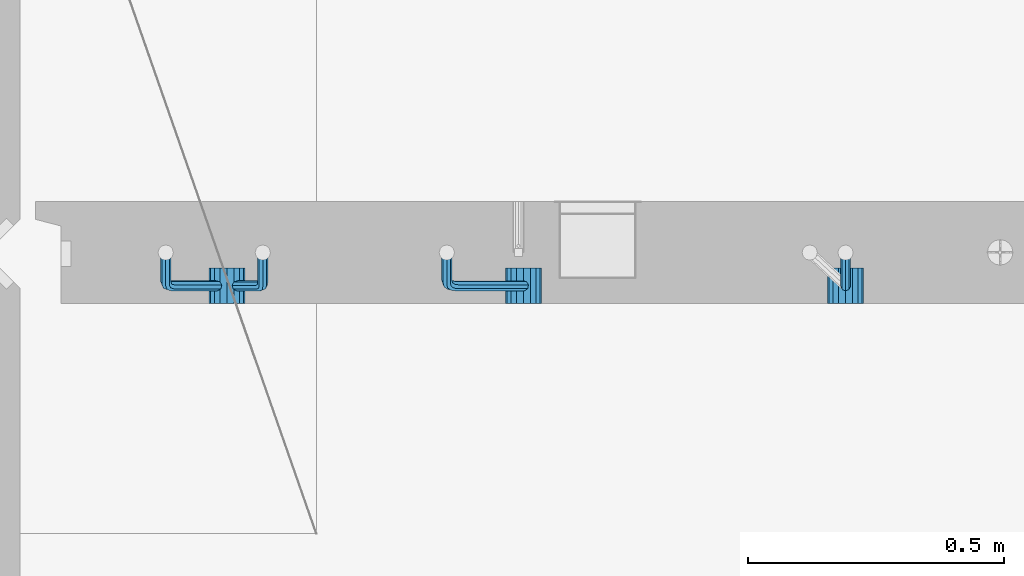
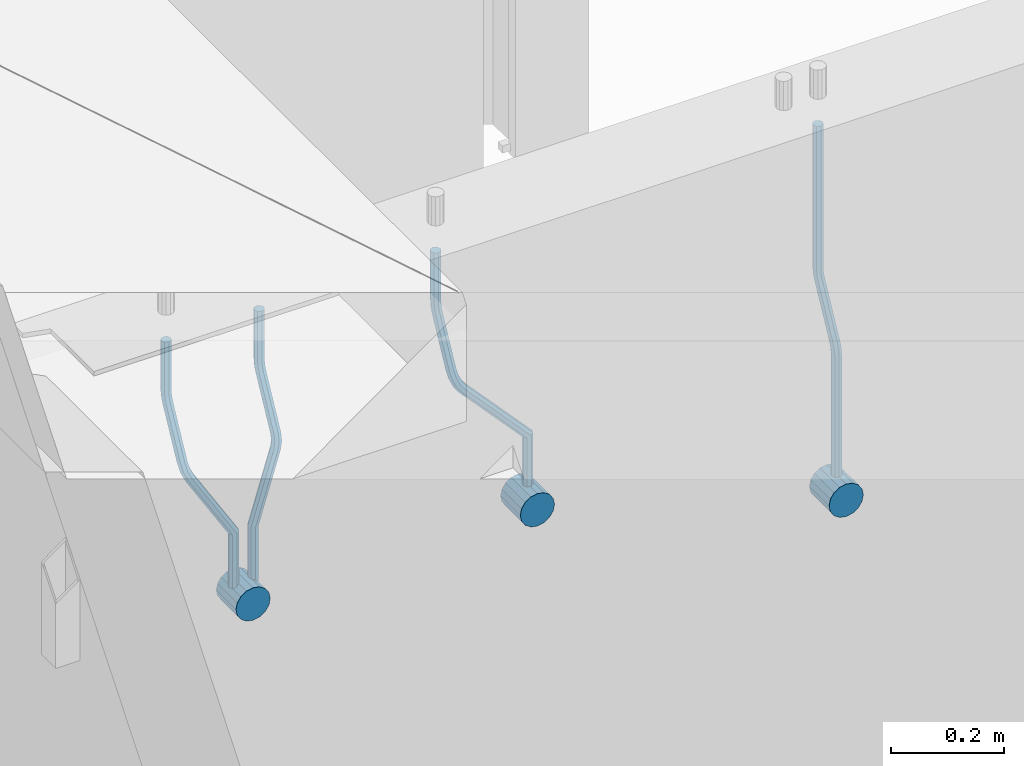
# One storey, part 155 of 350: 7 beams, 1 element without a shape of its own.
"""IFC2X3 building model written with IfcOpenShell, lengths in millimetres."""

from ifc_helpers import new_model, si_unit, frame, origin_with_axes, place, context, subcontext, project, spatial, faceted_brep, material, type_object, element, aggregate, save


model = new_model("IFC2X3")

# Units and contexts
model_context = context("Model", 3, precision=1e-05, world=origin_with_axes())
body_context = subcontext(model_context, "Body", "Model", "MODEL_VIEW")
ifc_project = project(units=[si_unit("LENGTHUNIT", "METRE", prefix="MILLI"), si_unit("AREAUNIT", "SQUARE_METRE"), si_unit("VOLUMEUNIT", "CUBIC_METRE"), si_unit("MASSUNIT", "GRAM", prefix="KILO"), si_unit("TIMEUNIT", "SECOND"), si_unit("PLANEANGLEUNIT", "RADIAN"), si_unit("SOLIDANGLEUNIT", "STERADIAN"), si_unit("THERMODYNAMICTEMPERATUREUNIT", "DEGREE_CELSIUS"), si_unit("LUMINOUSINTENSITYUNIT", "LUMEN")], contexts=[model_context])

# Site, building, storey
site_placement = place(None, origin_with_axes())
site = spatial("IfcSite", under=ifc_project, at=site_placement, CompositionType="ELEMENT")
building_placement = place(site_placement, origin_with_axes())
building = spatial("IfcBuilding", under=site, at=building_placement, CompositionType="ELEMENT")
storey_placement = place(building_placement, origin_with_axes())
storey = spatial("IfcBuildingStorey", under=building, at=storey_placement, Name="2", CompositionType="ELEMENT", Elevation=0.0)

# Assembly, beams
assembly_placement = place(storey_placement, origin_with_axes())
assembly = element("IfcElementAssembly", 1, at=assembly_placement, inside=storey, AssemblyPlace="NOTDEFINED", PredefinedType="REINFORCEMENT_UNIT")
ifc_material = material()
beam_type_1 = type_object("IfcBeamType", Name="D20", PredefinedType="NOTDEFINED")
beam_1_placement = place(assembly_placement, frame((9615.0034031366, 16979.9000008034, 87407.5), z_axis=(-0.000415599999849952, -0.999999913638316, 0.0), x_axis=(0.0, 0.0, -1.0)))
beam_1 = element("IfcBeam", 2, at=beam_1_placement, type_object=beam_type_1, material=ifc_material, Name="JM20", ObjectType="D20", context=body_context, shape_type="Brep", body=[
    faceted_brep([(0.0, -10.0, 0.0), (-4.19531716033816e-08, -7.07106781186667, -7.07106781187031), (308.817759199839, -7.07106784567077, -7.07106781098628), (308.817759199388, -10.0000000315576, 1.18961906991899e-09), (0.0, 0.0, -10.0), (308.817759200625, -3.38059180648997e-08, -9.99999999911961), (4.196772351861e-08, 7.07106781186303, -7.07106781186667), (308.817759201396, 7.07106777806075, -7.07106781098992), (0.0, 10.0, 0.0), (308.817759201687, 9.99999996619408, 8.76752892509103e-10), (4.196772351861e-08, 7.07106781185939, 7.07106781185939), (308.817759201353, 7.07106777805893, 7.07106781273978), (0.0, 0.0, 10.0), (308.817759200567, -3.38059180648997e-08, 10.0000000008768), (-4.19531716033816e-08, -7.07106781187031, 7.07106781185939), (308.817759199781, -7.07106784567259, 7.07106781274342), (323.108969574154, 0.000717635259206872, -8.27316123493802), (322.412036484602, -7.07038517474393, -5.42844102338131), (320.72809124495, -9.99940192615759, 1.43915193649809), (319.043566138222, -7.07055433041933, 8.30667482965873), (318.345233125816, 0.000478413006931078, 11.1512258851908), (319.042166215368, 7.07158122300643, 8.30650567364501), (320.726111455049, 10.0005979744237, 1.4389127137656), (322.410636561748, 7.07175037869092, -5.42861017940231), (335.221090258594, 7.07375888522984, -0.59577927861028), (336.577559329642, 0.00282932867594354, -3.19204402394098), (331.949003496353, 10.0023575726736, 5.67282516818887), (328.678043090971, 7.07309199865631, 11.9417058486688), (327.324293285914, 0.00188620863991673, 14.5386374811205), (328.680762356948, -7.06904334791398, 11.9423727357971), (331.952849119407, -9.99764203791528, 5.67376828873239), (335.223809524556, -7.06837646134409, -0.59511239150379), (438.031978881656, -7.04607830785426, 53.0582885393342), (434.761018476231, -9.97534387865016, 59.3271692200688), (439.385728686641, 0.0251274821457628, 50.4613569068679), (438.02925961549, 7.0960570387233, 53.0576216521513), (434.757172853177, 10.0246557262235, 59.326226098925), (431.486212447766, 7.0953901522571, 65.5951067794085), (430.132462642781, 0.0241843622607121, 68.1920384118748), (431.488931713931, -7.04674519431865, 65.5957736665914), (448.364788846782, 0.0265352911246737, 53.8487685030559), (447.667855771331, -7.04456751813632, 56.6934887198913), (445.983910537514, -9.97358426776555, 63.5610816819462), (444.29938542498, -7.04473667025195, 70.428604572935), (443.601052398531, 0.0262960739091795, 73.2731556232175), (444.297985473939, 7.09739888316835, 70.4284354063821), (445.981930707741, 10.0264156328012, 63.5608424443053), (447.666455820276, 7.09756803528398, 56.6933195533311), (457.892262743961, 7.0980815803614, 57.9289265681182), (457.892262772089, 0.0270137655697908, 54.999994387068), (457.892262732348, 10.0270137755506, 64.9999943770345), (457.892262744092, 7.09808159448221, 72.0710621918224), (457.89226277222, 0.0270137855477515, 74.9999943870425), (457.89226280032, -7.04405402924385, 72.0710622060069), (457.892262811918, -9.97298622770904, 64.9999943967923), (457.892262800189, -7.04405404336103, 57.9289265822954), (717.500000028129, -7.04405301280349, 57.928926581666), (717.500000039799, -9.97298519384276, 64.9999943964685), (717.499999999956, 0.0270147961218754, 54.999994386435), (717.499999971798, 7.09808261092803, 57.9289265674743), (717.499999960128, 10.0270148061572, 64.9999943763978), (717.499999971813, 7.09808262511979, 72.071062191204), (717.499999999985, 0.0270148161926045, 74.999994386435), (717.500000028143, -7.04405299861173, 72.0710622053957)], [[[0, 1, 2, 3]], [[1, 4, 5, 2]], [[4, 6, 7, 5]], [[6, 8, 9, 7]], [[8, 10, 11, 9]], [[10, 12, 13, 11]], [[12, 14, 15, 13]], [[14, 0, 3, 15]], [[14, 12, 10, 8, 6, 4, 1, 0]], [[2, 5, 16, 17]], [[3, 2, 17, 18]], [[15, 3, 18, 19]], [[13, 15, 19, 20]], [[11, 13, 20, 21]], [[9, 11, 21, 22]], [[7, 9, 22, 23]], [[5, 7, 23, 16]], [[23, 24, 25, 16]], [[22, 26, 24, 23]], [[21, 27, 26, 22]], [[20, 28, 27, 21]], [[19, 29, 28, 20]], [[18, 30, 29, 19]], [[17, 31, 30, 18]], [[16, 25, 31, 17]], [[30, 31, 32, 33]], [[31, 25, 34, 32]], [[25, 24, 35, 34]], [[24, 26, 36, 35]], [[26, 27, 37, 36]], [[27, 28, 38, 37]], [[28, 29, 39, 38]], [[29, 30, 33, 39]], [[32, 34, 40, 41]], [[33, 32, 41, 42]], [[39, 33, 42, 43]], [[38, 39, 43, 44]], [[37, 38, 44, 45]], [[36, 37, 45, 46]], [[35, 36, 46, 47]], [[34, 35, 47, 40]], [[47, 48, 49, 40]], [[46, 50, 48, 47]], [[45, 51, 50, 46]], [[44, 52, 51, 45]], [[43, 53, 52, 44]], [[42, 54, 53, 43]], [[41, 55, 54, 42]], [[40, 49, 55, 41]], [[54, 55, 56, 57]], [[55, 49, 58, 56]], [[49, 48, 59, 58]], [[48, 50, 60, 59]], [[50, 51, 61, 60]], [[51, 52, 62, 61]], [[52, 53, 63, 62]], [[53, 54, 57, 63]], [[58, 59, 60, 61, 62, 63, 57, 56]]]),
])
beam_2_placement = place(assembly_placement, frame((8835.00340324668, 16979.9000008034, 87407.5), z_axis=(-0.000415599999849952, -0.999999913638316, 0.0), x_axis=(0.0, 0.0, -1.0)))
beam_2 = element("IfcBeam", 3, at=beam_2_placement, type_object=beam_type_1, material=ifc_material, Name="JM20", ObjectType="D20", context=body_context, shape_type="Brep", body=[
    faceted_brep([(0.0, -10.0, 0.0), (-4.19531716033816e-08, -7.07106781186667, -7.07106781187031), (108.817745274035, -7.07106780534923, -7.07106781138282), (108.817745274282, -9.99999999387728, 6.25732354819775e-10), (0.0, 0.0, -10.0), (108.817745273627, 6.5174390329048e-09, -9.99999999951979), (4.196772351861e-08, 7.07106781186303, -7.07106781186667), (108.817745273191, 7.07106781838229, -7.07106781138646), (0.0, 10.0, 0.0), (108.817745272972, 10.0000000065156, 4.80213202536106e-10), (4.196772351861e-08, 7.07106781185939, 7.07106781185939), (108.817745273118, 7.07106781838047, 7.07106781234688), (0.0, 0.0, 10.0), (108.817745273511, 6.51562004350126e-09, 10.0000000004839), (-4.19531716033816e-08, -7.07106781187031, 7.07106781185939), (108.817745273947, -7.07106780535105, 7.07106781234688), (123.108954183059, 0.000717681035894202, -8.27316159443217), (122.412021172189, -7.07038512938016, -5.42844136475105), (120.72807610796, -9.99940188179062, 1.43915163770362), (119.043551170704, -7.07055428705462, 8.30667457294476), (118.345218222516, 0.000478455955089885, 11.1512256454189), (119.0421512334, 7.07158126637114, 8.30650541574869), (120.726096297614, 10.0005980187834, 1.43891241329038), (122.410621234856, 7.0717504240456, -5.42861052196531), (135.22107377628, 7.07375894905454, -0.595780608462519), (136.577542729705, 0.00282939387761871, -3.19204541917861), (131.948987323645, 10.0023576331841, 5.67282400158729), (128.678027238435, 7.07309205585807, 11.9417048475552), (127.324277576598, 0.00188626447015849, 14.5386365507547), (128.680746529979, -7.06904329070858, 11.9423717400241), (131.952832982774, -9.99764197422519, 5.67376712984333), (135.223793067897, -7.06837639751029, -0.595113715968182), (228.618473932263, -7.04811975626581, 48.1455814515648), (225.347513847039, -9.97738533437769, 54.4144622980784), (229.972223594217, 0.0230860351002775, 45.5486497482525), (228.615754640981, 7.0940155903063, 48.1449145588849), (225.343668188434, 10.0226142745032, 54.413519168902), (222.072708103209, 7.0933486972317, 60.6824000149136), (220.71895844127, 0.0221429058692593, 63.2793317182222), (222.075427394506, -7.04878664933858, 60.6830669075935), (242.359530626607, -5.11807977741773, 54.2178725378544), (240.589998539246, -7.8364579297413, 61.1502473240325), (237.467032239641, -4.88691414189452, 67.4847494116439), (234.820023031163, 2.00274883800921, 69.5107133886158), (234.199553008453, 8.79665987653607, 66.041357034137), (235.9690850958, 11.515038028856, 59.108982247948), (239.092051395462, 8.56549424101649, 52.7744801603476), (241.739060603926, 1.67583126110367, 50.7485161833647), (253.320593995435, 6.49475796966908, 54.0461912154642), (255.884193780192, 0.509358169847474, 58.0688258176233), (249.403367901468, 12.8559000820806, 55.7104792064529), (246.427173417251, 15.8665137298067, 62.0867724571763), (246.135424907392, 13.7630222690877, 69.4399248590198), (248.699024692221, 7.77762246929342, 73.462559461208), (252.616250786203, 1.41648035689104, 71.7982714702011), (255.592445270362, -1.59413329085874, 65.4219782194778), (263.775218458322, 14.0880763316163, 55.1735662778046), (268.092877162446, 9.37667043252804, 59.3853499298057), (258.711370403718, 19.6164132468075, 56.7142082202008), (255.867666511243, 22.72325639054, 63.1047886019151), (256.909909953785, 21.588659185405, 70.6017921067651), (261.227568657952, 16.8772532863513, 74.8135757587734), (266.291416712571, 11.348916371182, 73.2729338163554), (269.135120604697, 8.24207322799703, 66.8823534341354), (411.777331932535, 141.004054536572, 59.330645583992), (412.819575375106, 139.86945733149, 66.8276490888165), (407.459673228295, 145.71546043558, 55.1188619320019), (402.395825173633, 151.243797350722, 56.6595038743981), (399.552121281173, 154.350640494475, 63.0500842560868), (400.594364723744, 153.216043289394, 70.547087760915), (404.912023427984, 148.504637390388, 74.7588714129015), (409.975871482646, 142.976300475242, 73.2182294705053), (412.588360762704, 141.747027069805, 59.3303368045817), (413.18825896435, 140.207203377095, 66.8275087215443), (410.103187350978, 148.137147940774, 55.1178554785947), (407.188519608899, 155.634319848998, 56.6576791731022), (405.551730369989, 159.846801170075, 63.047800051525), (406.151628571635, 158.306977477367, 70.5449719684912), (408.636801983361, 151.916856606398, 74.7574532944818), (411.551469725426, 144.419684698174, 73.2176295999743), (413.688258959737, 141.747027073105, 59.3303368045781), (413.68825896435, 140.207203378595, 66.8275087215443), (413.688258940572, 148.137147951529, 55.1178554785911), (413.688258918075, 155.634319868494, 56.6576791730986), (413.688258905444, 159.846801194481, 63.0478000515213), (413.688258910042, 158.306977499973, 70.5449719684912), (413.688258929222, 151.916856621549, 74.7574532944782), (413.688258951704, 144.419684704584, 73.2176295999707), (517.499999574822, 141.74702738449, 59.3303368045817), (517.499999579435, 140.207203689981, 66.8275087215443), (517.499999555657, 148.137148262915, 55.1178554785947), (517.499999533175, 155.634320179879, 56.6576791731022), (517.499999520529, 159.846801505866, 63.047800051525), (517.499999525127, 158.306977811359, 70.5449719684912), (517.499999544307, 151.916856932934, 74.7574532944818), (517.499999566789, 144.41968501597, 73.2176295999743)], [[[0, 1, 2, 3]], [[1, 4, 5, 2]], [[4, 6, 7, 5]], [[6, 8, 9, 7]], [[8, 10, 11, 9]], [[10, 12, 13, 11]], [[12, 14, 15, 13]], [[14, 0, 3, 15]], [[14, 12, 10, 8, 6, 4, 1, 0]], [[2, 5, 16, 17]], [[3, 2, 17, 18]], [[15, 3, 18, 19]], [[13, 15, 19, 20]], [[11, 13, 20, 21]], [[9, 11, 21, 22]], [[7, 9, 22, 23]], [[5, 7, 23, 16]], [[23, 24, 25, 16]], [[22, 26, 24, 23]], [[21, 27, 26, 22]], [[20, 28, 27, 21]], [[19, 29, 28, 20]], [[18, 30, 29, 19]], [[17, 31, 30, 18]], [[16, 25, 31, 17]], [[30, 31, 32, 33]], [[31, 25, 34, 32]], [[25, 24, 35, 34]], [[24, 26, 36, 35]], [[26, 27, 37, 36]], [[27, 28, 38, 37]], [[28, 29, 39, 38]], [[29, 30, 33, 39]], [[33, 32, 40, 41]], [[39, 33, 41, 42]], [[38, 39, 42, 43]], [[37, 38, 43, 44]], [[36, 37, 44, 45]], [[35, 36, 45, 46]], [[34, 35, 46, 47]], [[32, 34, 47, 40]], [[47, 48, 49, 40]], [[46, 50, 48, 47]], [[45, 51, 50, 46]], [[44, 52, 51, 45]], [[43, 53, 52, 44]], [[42, 54, 53, 43]], [[41, 55, 54, 42]], [[40, 49, 55, 41]], [[48, 56, 57, 49]], [[50, 58, 56, 48]], [[51, 59, 58, 50]], [[52, 60, 59, 51]], [[53, 61, 60, 52]], [[54, 62, 61, 53]], [[55, 63, 62, 54]], [[49, 57, 63, 55]], [[63, 57, 64, 65]], [[57, 56, 66, 64]], [[56, 58, 67, 66]], [[58, 59, 68, 67]], [[59, 60, 69, 68]], [[60, 61, 70, 69]], [[61, 62, 71, 70]], [[62, 63, 65, 71]], [[65, 64, 72, 73]], [[64, 66, 74, 72]], [[66, 67, 75, 74]], [[67, 68, 76, 75]], [[68, 69, 77, 76]], [[69, 70, 78, 77]], [[70, 71, 79, 78]], [[71, 65, 73, 79]], [[73, 72, 80, 81]], [[72, 74, 82, 80]], [[74, 75, 83, 82]], [[75, 76, 84, 83]], [[76, 77, 85, 84]], [[77, 78, 86, 85]], [[78, 79, 87, 86]], [[79, 73, 81, 87]], [[81, 80, 88, 89]], [[80, 82, 90, 88]], [[82, 83, 91, 90]], [[83, 84, 92, 91]], [[84, 85, 93, 92]], [[85, 86, 94, 93]], [[86, 87, 95, 94]], [[87, 81, 89, 95]], [[90, 91, 92, 93, 94, 95, 89, 88]]]),
])
beam_3_placement = place(assembly_placement, frame((8475.00340324668, 16979.9000008034, 87407.5), z_axis=(-0.000415599999849952, -0.999999913638316, 0.0), x_axis=(0.0, 0.0, -1.0)))
beam_3 = element("IfcBeam", 4, at=beam_3_placement, type_object=beam_type_1, material=ifc_material, Name="JM20", ObjectType="D20", context=body_context, shape_type="Brep", body=[
    faceted_brep([(0.0, -10.0, 0.0), (-4.19531716033816e-08, -7.07106781186667, -7.07106781187031), (108.817745274035, -7.07106780534923, -7.07106781138282), (108.817745274282, -9.99999999387728, 6.25732354819775e-10), (0.0, 0.0, -10.0), (108.817745273627, 6.5174390329048e-09, -9.99999999951979), (4.196772351861e-08, 7.07106781186303, -7.07106781186667), (108.817745273191, 7.07106781838229, -7.07106781138646), (0.0, 10.0, 0.0), (108.817745272972, 10.0000000065156, 4.80213202536106e-10), (4.196772351861e-08, 7.07106781185939, 7.07106781185939), (108.817745273118, 7.07106781838047, 7.07106781234688), (0.0, 0.0, 10.0), (108.817745273511, 6.51562004350126e-09, 10.0000000004839), (-4.19531716033816e-08, -7.07106781187031, 7.07106781185939), (108.817745273947, -7.07106780535105, 7.07106781234688), (123.108954183059, 0.000717681035894202, -8.27316159443217), (122.412021172189, -7.07038512938016, -5.42844136475105), (120.72807610796, -9.99940188179062, 1.43915163770362), (119.043551170704, -7.07055428705462, 8.30667457294476), (118.345218222516, 0.000478455955089885, 11.1512256454189), (119.0421512334, 7.07158126637114, 8.30650541574869), (120.726096297614, 10.0005980187834, 1.43891241329038), (122.410621234856, 7.0717504240456, -5.42861052196531), (135.22107377628, 7.07375894905454, -0.595780608462519), (136.577542729705, 0.00282939387761871, -3.19204541917861), (131.948987323645, 10.0023576331841, 5.67282400158729), (128.678027238435, 7.07309205585807, 11.9417048475552), (127.324277576598, 0.00188626447015849, 14.5386365507547), (128.680746529979, -7.06904329070858, 11.9423717400241), (131.952832982774, -9.99764197422519, 5.67376712984333), (135.223793067897, -7.06837639751029, -0.595113715968182), (236.184987141853, -7.04647863304126, 52.0943835719445), (232.914027056744, -9.97574421112949, 58.3632644184945), (237.538736803792, 0.0247271583230031, 49.4974518686358), (236.182267850556, 7.09565671352902, 52.093716679261), (232.910181397994, 10.0242553977168, 58.3623212892744), (229.639221312784, 7.0949898204417, 64.631202135286), (228.28547165083, 0.0237840290774329, 67.2281338385947), (229.64194060408, -7.04714552612859, 64.6318690279659), (248.6361426574, 6.07228546495571, 56.8411920703111), (248.347225361111, -0.863437898962729, 53.6176983169717), (246.616285773896, -7.90364889308694, 56.0708434545886), (244.457284830249, -10.9242873990424, 62.7636083320067), (243.134936001807, -8.15590434705155, 69.7754620538217), (243.423853298023, -1.22018098313129, 72.9989558071647), (245.154792885252, 5.82003001100384, 70.5458106695442), (247.313793828915, 8.84066851695206, 63.8530457921224), (262.262810178814, 5.37582167724941, 65.733133839356), (261.561593060862, 3.07645584421334, 58.4667829613572), (261.257873569193, 2.08769693226714, 72.5710415482208), (259.135461468584, -4.86177950991259, 74.9749524903455), (257.138854100602, -11.4016986008392, 71.5366882385752), (256.437636982591, -13.7010644331713, 64.2703373600561), (257.442573592241, -10.4129396888893, 57.4324296517152), (259.564985692865, -3.46346324671867, 55.0285187095906), (405.56030258059, -55.6424869289785, 57.4512270528103), (404.555365971013, -58.9306116739535, 64.2891347616751), (407.682714681185, -48.6930104868225, 55.0473161106529), (409.679322049255, -42.153091395905, 58.4855803623905), (410.380539167294, -39.8537255628671, 65.7519312403674), (409.375602557717, -43.1418503078439, 72.5898389492322), (407.253190457122, -50.09132675, 74.993749891386), (405.256583089053, -56.6312458409175, 71.5554856396557), (408.394915116543, -56.5080702894629, 57.4515867892878), (407.881249744809, -59.9462106727442, 64.2895568446584), (409.479769216079, -49.2417629119063, 55.0475441721828), (410.500319225088, -42.4037928534744, 58.4856845539216), (410.858740789379, -39.9997502352981, 65.751991928224), (410.345075417616, -43.4378906185757, 72.5899619835945), (409.26022131808, -50.7041979961323, 74.9940046006996), (408.239671309086, -57.5421680545642, 71.5558642189608), (411.358740838899, -56.5080702805735, 57.4515867892915), (411.358740849202, -59.9462106623123, 64.2895568446584), (411.358740817101, -49.2417629062693, 55.0475441721828), (411.358740796582, -42.4037928508988, 58.4856845539216), (411.358740789379, -39.9997502337974, 65.751991928224), (411.358740799667, -43.4378906155343, 72.5899619835945), (411.358740821452, -50.7041979898386, 74.9940046006996), (411.35874084197, -57.5421680452091, 71.5558642189608), (527.500000169515, -56.5080699322043, 57.4515867892878), (527.500000179818, -59.9462103139449, 64.2895568446584), (527.500000147716, -49.2417625579019, 55.0475441721828), (527.500000127198, -42.4037925025295, 58.4856845539216), (527.500000119981, -39.9997498854282, 65.751991928224), (527.500000130283, -43.4378902671669, 72.5899619835945), (527.500000152068, -50.7041976414694, 74.9940046006996), (527.500000172586, -57.5421676968399, 71.5558642189608)], [[[0, 1, 2, 3]], [[1, 4, 5, 2]], [[4, 6, 7, 5]], [[6, 8, 9, 7]], [[8, 10, 11, 9]], [[10, 12, 13, 11]], [[12, 14, 15, 13]], [[14, 0, 3, 15]], [[14, 12, 10, 8, 6, 4, 1, 0]], [[2, 5, 16, 17]], [[3, 2, 17, 18]], [[15, 3, 18, 19]], [[13, 15, 19, 20]], [[11, 13, 20, 21]], [[9, 11, 21, 22]], [[7, 9, 22, 23]], [[5, 7, 23, 16]], [[23, 24, 25, 16]], [[22, 26, 24, 23]], [[21, 27, 26, 22]], [[20, 28, 27, 21]], [[19, 29, 28, 20]], [[18, 30, 29, 19]], [[17, 31, 30, 18]], [[16, 25, 31, 17]], [[30, 31, 32, 33]], [[31, 25, 34, 32]], [[25, 24, 35, 34]], [[24, 26, 36, 35]], [[26, 27, 37, 36]], [[27, 28, 38, 37]], [[28, 29, 39, 38]], [[29, 30, 33, 39]], [[34, 35, 40, 41]], [[32, 34, 41, 42]], [[33, 32, 42, 43]], [[39, 33, 43, 44]], [[38, 39, 44, 45]], [[37, 38, 45, 46]], [[36, 37, 46, 47]], [[35, 36, 47, 40]], [[47, 48, 49, 40]], [[46, 50, 48, 47]], [[45, 51, 50, 46]], [[44, 52, 51, 45]], [[43, 53, 52, 44]], [[42, 54, 53, 43]], [[41, 55, 54, 42]], [[40, 49, 55, 41]], [[53, 54, 56, 57]], [[54, 55, 58, 56]], [[55, 49, 59, 58]], [[49, 48, 60, 59]], [[48, 50, 61, 60]], [[50, 51, 62, 61]], [[51, 52, 63, 62]], [[52, 53, 57, 63]], [[57, 56, 64, 65]], [[56, 58, 66, 64]], [[58, 59, 67, 66]], [[59, 60, 68, 67]], [[60, 61, 69, 68]], [[61, 62, 70, 69]], [[62, 63, 71, 70]], [[63, 57, 65, 71]], [[65, 64, 72, 73]], [[64, 66, 74, 72]], [[66, 67, 75, 74]], [[67, 68, 76, 75]], [[68, 69, 77, 76]], [[69, 70, 78, 77]], [[70, 71, 79, 78]], [[71, 65, 73, 79]], [[73, 72, 80, 81]], [[72, 74, 82, 80]], [[74, 75, 83, 82]], [[75, 76, 84, 83]], [[76, 77, 85, 84]], [[77, 78, 86, 85]], [[78, 79, 87, 86]], [[79, 73, 81, 87]], [[82, 83, 84, 85, 86, 87, 81, 80]]]),
])
beam_4_placement = place(assembly_placement, frame((8285.00340324668, 16979.9000008034, 87407.5), z_axis=(-0.000415599999849952, -0.999999913638316, 0.0), x_axis=(0.0, 0.0, -1.0)))
beam_4 = element("IfcBeam", 5, at=beam_4_placement, type_object=beam_type_1, material=ifc_material, Name="JM20", ObjectType="D20", context=body_context, shape_type="Brep", body=[
    faceted_brep([(0.0, -10.0, 0.0), (-4.19531716033816e-08, -7.07106781186667, -7.07106781187031), (108.817745274035, -7.07106780534923, -7.07106781138282), (108.817745274282, -9.99999999387728, 6.25732354819775e-10), (0.0, 0.0, -10.0), (108.817745273627, 6.5174390329048e-09, -9.99999999951979), (4.196772351861e-08, 7.07106781186303, -7.07106781186667), (108.817745273191, 7.07106781838229, -7.07106781138646), (0.0, 10.0, 0.0), (108.817745272972, 10.0000000065156, 4.80213202536106e-10), (4.196772351861e-08, 7.07106781185939, 7.07106781185939), (108.817745273118, 7.07106781838047, 7.07106781234688), (0.0, 0.0, 10.0), (108.817745273511, 6.51562004350126e-09, 10.0000000004839), (-4.19531716033816e-08, -7.07106781187031, 7.07106781185939), (108.817745273947, -7.07106780535105, 7.07106781234688), (123.108954183059, 0.000717681035894202, -8.27316159443217), (122.412021172189, -7.07038512938016, -5.42844136475105), (120.72807610796, -9.99940188179062, 1.43915163770362), (119.043551170704, -7.07055428705462, 8.30667457294476), (118.345218222516, 0.000478455955089885, 11.1512256454189), (119.0421512334, 7.07158126637114, 8.30650541574869), (120.726096297614, 10.0005980187834, 1.43891241329038), (122.410621234856, 7.0717504240456, -5.42861052196531), (135.22107377628, 7.07375894905454, -0.595780608462519), (136.577542729705, 0.00282939387761871, -3.19204541917861), (131.948987323645, 10.0023576331841, 5.67282400158729), (128.678027238435, 7.07309205585807, 11.9417048475552), (127.324277576598, 0.00188626447015849, 14.5386365507547), (128.680746529979, -7.06904329070858, 11.9423717400241), (131.952832982774, -9.99764197422519, 5.67376712984333), (135.223793067897, -7.06837639751029, -0.595113715968182), (232.402437428042, -7.04729904112355, 50.1203514230874), (229.131477342933, -9.97656461926999, 56.3892322695465), (233.756187089995, 0.0239067502407124, 47.5234197197824), (232.399718136745, 7.09483630544673, 50.1196845304112), (229.127631684183, 10.0234349896364, 56.3882891404246), (225.856671598973, 7.09416941235941, 62.6571699864289), (224.502921937034, 0.0229636209951423, 65.2541016897412), (225.859390890269, -7.04796593420906, 62.6578368791124), (249.189096393879, -4.47246690703469, 56.6819566015656), (248.077205390815, -7.070562329116, 63.794778990592), (245.438615273073, -4.04479441522199, 70.3110060036124), (242.818976346156, 2.83238302726022, 72.4135202319376), (241.752837564854, 9.53241272338892, 68.8706973556764), (242.864728567991, 12.130508145472, 61.7578749666827), (245.503318685674, 9.10474023159077, 55.2416479536478), (248.122957612577, 2.22756278908673, 53.1391337253044), (262.227655998417, 8.55574368060479, 55.0905560343417), (265.66954071114, 2.92161058118472, 58.9620696407692), (258.367889273839, 14.876528294435, 57.021495303452), (256.351239537093, 18.1813345207174, 63.6237694123665), (257.359032853405, 16.5342516931214, 71.0298557306051), (260.800917566128, 10.9001185936977, 74.9013693370434), (264.660684290735, 4.57933397990018, 72.9704300679259), (266.677334027001, 1.27452775464917, 66.3681559586585), (410.721160764631, 91.5081613346811, 58.9252530669619), (411.728954081002, 89.861078507096, 66.3313393852004), (407.279276051908, 97.1422944340902, 55.053739460498), (403.419509327403, 103.46307904791, 56.9846787295719), (401.402859590729, 106.767885274196, 63.5869528384683), (402.410652907114, 105.12080244661, 70.9930391567141), (405.852537619838, 99.4866693472013, 74.8645527631779), (409.712304344357, 93.1658847333838, 72.9336134941077), (411.611923002652, 92.0521714889783, 58.9250269763252), (412.155668410225, 90.1216833219078, 66.3312310778347), (409.754886469877, 98.6542099015223, 55.0531111083837), (407.672385626982, 106.060413996784, 56.9835992770786), (406.584321224072, 109.932329861462, 63.5856376951961), (407.12806663166, 108.001841694397, 70.9918417967092), (408.985103164436, 101.399803281851, 74.8637576646506), (411.06760400733, 93.9935991865859, 72.9332694959521), (412.655668404448, 92.0521714921069, 58.9250269763288), (412.655668410225, 90.1216833234084, 66.3312310778347), (412.655668384643, 98.6542099102207, 55.0531111083837), (412.655668362422, 106.06041401173, 56.9835992770822), (412.65566835081, 109.932329879672, 63.5856376951961), (412.655668356587, 108.001841710977, 70.9918417967056), (412.655668376392, 101.399803292861, 74.8637576646506), (412.655668398613, 93.9935991913499, 72.9332694959521), (527.499999723892, 92.0521718365853, 58.9250269763252), (527.499999729669, 90.1216836678886, 66.3312310778347), (527.499999704101, 98.6542102546991, 55.0531111083837), (527.499999681881, 106.060414356209, 56.9835992770786), (527.499999670254, 109.93233022415, 63.5856376951924), (527.499999676045, 108.001842055455, 70.9918417967056), (527.499999695836, 101.399803637341, 74.863757664647), (527.499999718057, 93.9935995358301, 72.9332694959521)], [[[0, 1, 2, 3]], [[1, 4, 5, 2]], [[4, 6, 7, 5]], [[6, 8, 9, 7]], [[8, 10, 11, 9]], [[10, 12, 13, 11]], [[12, 14, 15, 13]], [[14, 0, 3, 15]], [[14, 12, 10, 8, 6, 4, 1, 0]], [[2, 5, 16, 17]], [[3, 2, 17, 18]], [[15, 3, 18, 19]], [[13, 15, 19, 20]], [[11, 13, 20, 21]], [[9, 11, 21, 22]], [[7, 9, 22, 23]], [[5, 7, 23, 16]], [[23, 24, 25, 16]], [[22, 26, 24, 23]], [[21, 27, 26, 22]], [[20, 28, 27, 21]], [[19, 29, 28, 20]], [[18, 30, 29, 19]], [[17, 31, 30, 18]], [[16, 25, 31, 17]], [[30, 31, 32, 33]], [[31, 25, 34, 32]], [[25, 24, 35, 34]], [[24, 26, 36, 35]], [[26, 27, 37, 36]], [[27, 28, 38, 37]], [[28, 29, 39, 38]], [[29, 30, 33, 39]], [[33, 32, 40, 41]], [[39, 33, 41, 42]], [[38, 39, 42, 43]], [[37, 38, 43, 44]], [[36, 37, 44, 45]], [[35, 36, 45, 46]], [[34, 35, 46, 47]], [[32, 34, 47, 40]], [[47, 48, 49, 40]], [[46, 50, 48, 47]], [[45, 51, 50, 46]], [[44, 52, 51, 45]], [[43, 53, 52, 44]], [[42, 54, 53, 43]], [[41, 55, 54, 42]], [[40, 49, 55, 41]], [[55, 49, 56, 57]], [[49, 48, 58, 56]], [[48, 50, 59, 58]], [[50, 51, 60, 59]], [[51, 52, 61, 60]], [[52, 53, 62, 61]], [[53, 54, 63, 62]], [[54, 55, 57, 63]], [[57, 56, 64, 65]], [[56, 58, 66, 64]], [[58, 59, 67, 66]], [[59, 60, 68, 67]], [[60, 61, 69, 68]], [[61, 62, 70, 69]], [[62, 63, 71, 70]], [[63, 57, 65, 71]], [[65, 64, 72, 73]], [[64, 66, 74, 72]], [[66, 67, 75, 74]], [[67, 68, 76, 75]], [[68, 69, 77, 76]], [[69, 70, 78, 77]], [[70, 71, 79, 78]], [[71, 65, 73, 79]], [[73, 72, 80, 81]], [[72, 74, 82, 80]], [[74, 75, 83, 82]], [[75, 76, 84, 83]], [[76, 77, 85, 84]], [[77, 78, 86, 85]], [[78, 79, 87, 86]], [[79, 73, 81, 87]], [[82, 83, 84, 85, 86, 87, 81, 80]]]),
])
beam_type_2 = type_object("IfcBeamType", Name="D70", PredefinedType="NOTDEFINED")
beam_5_placement = place(assembly_placement, frame((9615.00340323833, 16879.9000008034, 86654.9999989631), z_axis=(0.0, 0.0, 1.0), x_axis=(0.0, 1.0, 0.0)))
beam_5 = element("IfcBeam", 6, at=beam_5_placement, type_object=beam_type_2, material=ifc_material, ObjectType="D70", context=body_context, shape_type="Brep", body=[
    faceted_brep([(0.0, -35.0, 0.0), (0.0, -32.3357836378964, -13.3939201327739), (70.0, -32.3357836378964, -13.3939201327739), (70.0, -35.0, 0.0), (0.0, -24.7487373415279, -24.7487373415352), (70.0, -24.7487373415279, -24.7487373415352), (0.0, -13.3939201327776, -32.3357836379), (70.0, -13.3939201327776, -32.3357836379), (0.0, 0.0, -35.0), (70.0, 0.0, -35.0), (0.0, 13.3939201327776, -32.3357836379), (70.0, 13.3939201327776, -32.3357836379), (0.0, 24.7487373415279, -24.7487373415352), (70.0, 24.7487373415279, -24.7487373415352), (0.0, 32.3357836378964, -13.3939201327739), (70.0, 32.3357836378964, -13.3939201327739), (0.0, 35.0, 0.0), (70.0, 35.0, 0.0), (0.0, 32.3357836378964, 13.3939201327739), (70.0, 32.3357836378964, 13.3939201327739), (0.0, 24.7487373415279, 24.7487373415352), (70.0, 24.7487373415279, 24.7487373415352), (0.0, 13.3939201327776, 32.3357836379), (70.0, 13.3939201327776, 32.3357836379), (0.0, 0.0, 35.0), (70.0, 0.0, 35.0), (0.0, -13.3939201327776, 32.3357836379), (70.0, -13.3939201327776, 32.3357836379), (0.0, -24.7487373415279, 24.7487373415352), (70.0, -24.7487373415279, 24.7487373415352), (0.0, -32.3357836378964, 13.3939201327739), (70.0, -32.3357836378964, 13.3939201327739)], [[[0, 1, 2, 3]], [[1, 4, 5, 2]], [[4, 6, 7, 5]], [[6, 8, 9, 7]], [[8, 10, 11, 9]], [[10, 12, 13, 11]], [[12, 14, 15, 13]], [[14, 16, 17, 15]], [[16, 18, 19, 17]], [[18, 20, 21, 19]], [[20, 22, 23, 21]], [[22, 24, 25, 23]], [[24, 26, 27, 25]], [[26, 28, 29, 27]], [[28, 30, 31, 29]], [[30, 0, 3, 31]], [[5, 7, 9, 11, 13, 15, 17, 19, 21, 23, 25, 27, 29, 31, 3, 2]], [[30, 28, 26, 24, 22, 20, 18, 16, 14, 12, 10, 8, 6, 4, 1, 0]]]),
])
beam_6_placement = place(assembly_placement, frame((8985.00340323833, 16879.9000008034, 86854.9999989631), z_axis=(0.0, 0.0, 1.0), x_axis=(0.0, 1.0, 0.0)))
beam_6 = element("IfcBeam", 7, at=beam_6_placement, type_object=beam_type_2, material=ifc_material, ObjectType="D70", context=body_context, shape_type="Brep", body=[
    faceted_brep([(0.0, -35.0, 0.0), (0.0, -32.3357836378964, -13.3939201327739), (70.0, -32.3357836378964, -13.3939201327739), (70.0, -35.0, 0.0), (0.0, -24.7487373415279, -24.7487373415352), (70.0, -24.7487373415279, -24.7487373415352), (0.0, -13.3939201327776, -32.3357836379), (70.0, -13.3939201327776, -32.3357836379), (0.0, 0.0, -35.0), (70.0, 0.0, -35.0), (0.0, 13.3939201327776, -32.3357836379), (70.0, 13.3939201327776, -32.3357836379), (0.0, 24.7487373415279, -24.7487373415352), (70.0, 24.7487373415279, -24.7487373415352), (0.0, 32.3357836378964, -13.3939201327739), (70.0, 32.3357836378964, -13.3939201327739), (0.0, 35.0, 0.0), (70.0, 35.0, 0.0), (0.0, 32.3357836378964, 13.3939201327739), (70.0, 32.3357836378964, 13.3939201327739), (0.0, 24.7487373415279, 24.7487373415352), (70.0, 24.7487373415279, 24.7487373415352), (0.0, 13.3939201327776, 32.3357836379), (70.0, 13.3939201327776, 32.3357836379), (0.0, 0.0, 35.0), (70.0, 0.0, 35.0), (0.0, -13.3939201327776, 32.3357836379), (70.0, -13.3939201327776, 32.3357836379), (0.0, -24.7487373415279, 24.7487373415352), (70.0, -24.7487373415279, 24.7487373415352), (0.0, -32.3357836378964, 13.3939201327739), (70.0, -32.3357836378964, 13.3939201327739)], [[[0, 1, 2, 3]], [[1, 4, 5, 2]], [[4, 6, 7, 5]], [[6, 8, 9, 7]], [[8, 10, 11, 9]], [[10, 12, 13, 11]], [[12, 14, 15, 13]], [[14, 16, 17, 15]], [[16, 18, 19, 17]], [[18, 20, 21, 19]], [[20, 22, 23, 21]], [[22, 24, 25, 23]], [[24, 26, 27, 25]], [[26, 28, 29, 27]], [[28, 30, 31, 29]], [[30, 0, 3, 31]], [[5, 7, 9, 11, 13, 15, 17, 19, 21, 23, 25, 27, 29, 31, 3, 2]], [[30, 28, 26, 24, 22, 20, 18, 16, 14, 12, 10, 8, 6, 4, 1, 0]]]),
])
beam_7_placement = place(assembly_placement, frame((8405.00340323833, 16879.9000008034, 86854.9999989631), z_axis=(0.0, 0.0, 1.0), x_axis=(0.0, 1.0, 0.0)))
beam_7 = element("IfcBeam", 8, at=beam_7_placement, type_object=beam_type_2, material=ifc_material, ObjectType="D70", context=body_context, shape_type="Brep", body=[
    faceted_brep([(0.0, -35.0, 0.0), (0.0, -32.3357836378964, -13.3939201327739), (70.0, -32.3357836378964, -13.3939201327739), (70.0, -35.0, 0.0), (0.0, -24.7487373415279, -24.7487373415352), (70.0, -24.7487373415279, -24.7487373415352), (0.0, -13.3939201327776, -32.3357836379), (70.0, -13.3939201327776, -32.3357836379), (0.0, 0.0, -35.0), (70.0, 0.0, -35.0), (0.0, 13.3939201327776, -32.3357836379), (70.0, 13.3939201327776, -32.3357836379), (0.0, 24.7487373415279, -24.7487373415352), (70.0, 24.7487373415279, -24.7487373415352), (0.0, 32.3357836378964, -13.3939201327739), (70.0, 32.3357836378964, -13.3939201327739), (0.0, 35.0, 0.0), (70.0, 35.0, 0.0), (0.0, 32.3357836378964, 13.3939201327739), (70.0, 32.3357836378964, 13.3939201327739), (0.0, 24.7487373415279, 24.7487373415352), (70.0, 24.7487373415279, 24.7487373415352), (0.0, 13.3939201327776, 32.3357836379), (70.0, 13.3939201327776, 32.3357836379), (0.0, 0.0, 35.0), (70.0, 0.0, 35.0), (0.0, -13.3939201327776, 32.3357836379), (70.0, -13.3939201327776, 32.3357836379), (0.0, -24.7487373415279, 24.7487373415352), (70.0, -24.7487373415279, 24.7487373415352), (0.0, -32.3357836378964, 13.3939201327739), (70.0, -32.3357836378964, 13.3939201327739)], [[[0, 1, 2, 3]], [[1, 4, 5, 2]], [[4, 6, 7, 5]], [[6, 8, 9, 7]], [[8, 10, 11, 9]], [[10, 12, 13, 11]], [[12, 14, 15, 13]], [[14, 16, 17, 15]], [[16, 18, 19, 17]], [[18, 20, 21, 19]], [[20, 22, 23, 21]], [[22, 24, 25, 23]], [[24, 26, 27, 25]], [[26, 28, 29, 27]], [[28, 30, 31, 29]], [[30, 0, 3, 31]], [[5, 7, 9, 11, 13, 15, 17, 19, 21, 23, 25, 27, 29, 31, 3, 2]], [[30, 28, 26, 24, 22, 20, 18, 16, 14, 12, 10, 8, 6, 4, 1, 0]]]),
])
aggregate(assembly, [beam_5, beam_1, beam_6, beam_2, beam_3, beam_7, beam_4])

save(model, "model.ifc")
